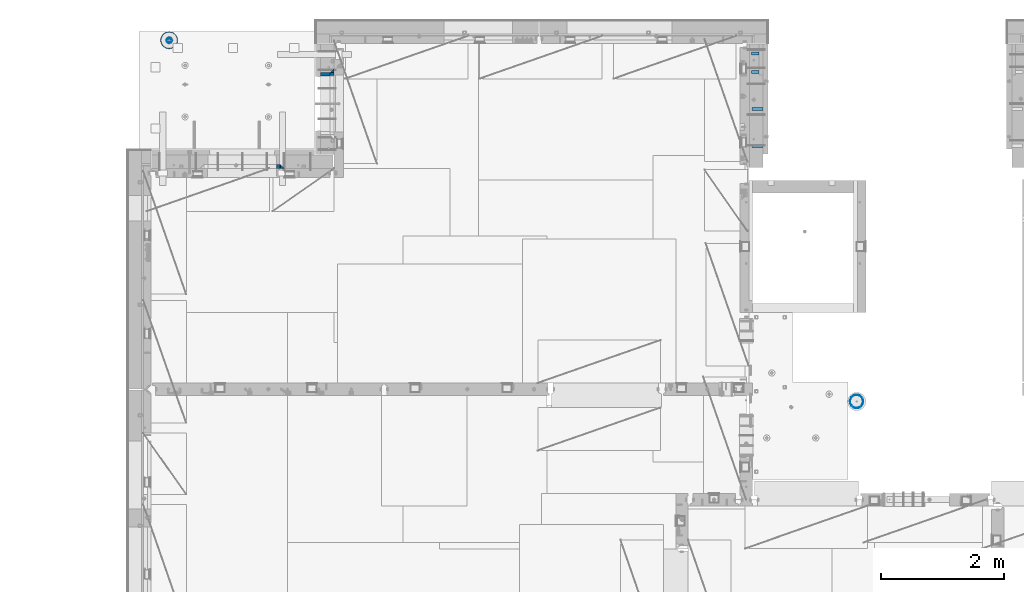
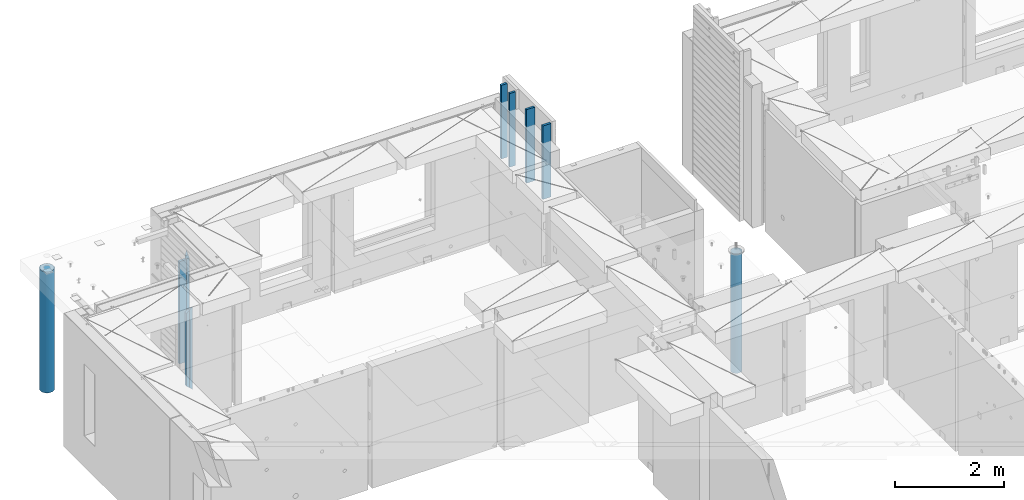
# One storey, part 4 of 309: 11 columns, 6 elements without a shape of their own.
"""IFC2X3 building model written with IfcOpenShell, lengths in millimetres."""

from ifc_helpers import new_model, si_unit, frame, origin_with_axes, place, context, subcontext, project, spatial, faceted_brep, material, type_object, element, aggregate, save


model = new_model("IFC2X3")

# Units and contexts
model_context = context("Model", 3, precision=1e-05, world=origin_with_axes())
body_context = subcontext(model_context, "Body", "Model", "MODEL_VIEW")
ifc_project = project(units=[si_unit("LENGTHUNIT", "METRE", prefix="MILLI"), si_unit("AREAUNIT", "SQUARE_METRE"), si_unit("VOLUMEUNIT", "CUBIC_METRE"), si_unit("MASSUNIT", "GRAM", prefix="KILO"), si_unit("TIMEUNIT", "SECOND"), si_unit("PLANEANGLEUNIT", "RADIAN"), si_unit("SOLIDANGLEUNIT", "STERADIAN"), si_unit("THERMODYNAMICTEMPERATUREUNIT", "DEGREE_CELSIUS"), si_unit("LUMINOUSINTENSITYUNIT", "LUMEN")], contexts=[model_context])

# Site, building, storey
site_placement = place(None, origin_with_axes())
site = spatial("IfcSite", under=ifc_project, at=site_placement, CompositionType="ELEMENT")
building_placement = place(site_placement, origin_with_axes())
building = spatial("IfcBuilding", under=site, at=building_placement, CompositionType="ELEMENT")
storey_placement = place(building_placement, origin_with_axes())
storey = spatial("IfcBuildingStorey", under=building, at=storey_placement, Name="7", CompositionType="ELEMENT", Elevation=0.0)

# Assembly, columns
assembly_1_placement = place(storey_placement, origin_with_axes())
assembly_1 = element("IfcElementAssembly", 1, at=assembly_1_placement, inside=storey, AssemblyPlace="NOTDEFINED", PredefinedType="REINFORCEMENT_UNIT")
ifc_material_1 = material(Name="CONCRETE/C25/30")
column_type_1 = type_object("IfcColumnType", PredefinedType="NOTDEFINED")
column_1_placement = place(assembly_1_placement, frame((10955.0, 22174.9998901814, 99755.0), z_axis=(0.0, -1.0, 0.0), x_axis=(0.0, 0.0, 1.0)))
column_1 = element("IfcColumn", 2, at=column_1_placement, type_object=column_type_1, material=ifc_material_1, Name="SK", context=body_context, shape_type="Brep", body=[
    faceted_brep([(0.0, -35.0, 35.0), (0.0, 35.0, 35.0), (0.0, -35.0, -35.0), (2420.0, -35.0, -35.0), (2349.99999999999, -35.0, 35.0), (2349.99999999999, 35.0, 35.0)], [[[0, 1, 2]], [[0, 2, 3, 4]], [[1, 0, 4, 5]], [[2, 1, 5, 3]], [[3, 5, 4]]]),
])
column_type_2 = type_object("IfcColumnType", PredefinedType="NOTDEFINED")
column_2_placement = place(assembly_1_placement, frame((10955.0, 22114.9998901814, 99755.0), z_axis=(0.0, -1.0, 0.0), x_axis=(0.0, 0.0, 1.0)))
column_2 = element("IfcColumn", 3, at=column_2_placement, type_object=column_type_2, material=ifc_material_1, Name="SK", context=body_context, shape_type="Brep", body=[
    faceted_brep([(0.0, 35.0, -25.0), (0.0, -35.0, -25.0), (0.0, -35.0, 18.8457723764259), (0.0, 35.0, 20.640644171297), (2350.0, -35.0, -25.0), (2306.15384615384, -35.0, 18.8457723764295), (2304.35897435897, 35.0, 20.6406441713007), (2350.0, 35.0, -25.0)], [[[0, 1, 2, 3]], [[2, 1, 4, 5]], [[3, 2, 5, 6]], [[0, 3, 6, 7]], [[7, 4, 1, 0]], [[4, 7, 6, 5]]]),
])
ifc_material_2 = material(Name="TIMBER")
column_type_3 = type_object("IfcColumnType", Name="50X150", PredefinedType="NOTDEFINED")
column_3_placement = place(assembly_1_placement, frame((10845.0, 22114.9998901814, 99760.0), z_axis=(0.0, -1.0, 0.0), x_axis=(0.0, 0.0, 1.0)))
column_3 = element("IfcColumn", 4, at=column_3_placement, type_object=column_type_3, material=ifc_material_2, ObjectType="50X150", context=body_context, shape_type="Brep", body=[
    faceted_brep([(0.0, 75.0, -25.0), (1.81898940354586e-12, 75.0, 25.0), (2295.00000000001, 75.0, 25.0), (2295.0, 75.0, -25.0), (1.81898940354586e-12, -75.0000000000009, 25.0), (2295.00000000001, -75.0, 25.0), (0.0, -75.0, -25.0), (2295.0, -75.0, -25.0)], [[[0, 1, 2, 3]], [[1, 4, 5, 2]], [[4, 6, 7, 5]], [[6, 0, 3, 7]], [[5, 7, 3, 2]], [[6, 4, 1, 0]]]),
])
aggregate(assembly_1, [column_1, column_2, column_3])

assembly_2_placement = place(storey_placement, origin_with_axes())
assembly_2 = element("IfcElementAssembly", 5, at=assembly_2_placement, inside=storey, AssemblyPlace="NOTDEFINED", PredefinedType="REINFORCEMENT_UNIT")
ifc_material_3 = material(Name="TIMBER/T24")
column_type_4 = type_object("IfcColumnType", Name="PK50X125", PredefinedType="NOTDEFINED")
column_4_placement = place(assembly_2_placement, frame((17857.5, 22455.0, 101690.0), z_axis=(-1.0, 3.00000001838171e-08, 0.0), x_axis=(0.0, 0.0, 1.0)))
column_4 = element("IfcColumn", 6, at=column_4_placement, type_object=column_type_4, material=ifc_material_3, ObjectType="PK50X125", context=body_context, shape_type="Brep", body=[
    faceted_brep([(0.0, 25.0, 62.5), (0.0, -25.0, 62.5), (1650.0, -25.0, 62.5), (1650.0, 25.0, 62.5), (0.0, -25.0, -62.5), (1650.0, -25.0, -62.5), (0.0, 25.0, -62.5), (1650.0, 25.0, -62.5)], [[[0, 1, 2, 3]], [[1, 4, 5, 2]], [[4, 6, 7, 5]], [[6, 0, 3, 7]], [[5, 7, 3, 2]], [[6, 4, 1, 0]]]),
])
column_5_placement = place(assembly_2_placement, frame((17857.5, 22150.0, 101690.0), z_axis=(-1.0, 3.00000001838171e-08, 0.0), x_axis=(0.0, 0.0, 1.0)))
column_5 = element("IfcColumn", 7, at=column_5_placement, type_object=column_type_4, material=ifc_material_3, ObjectType="PK50X125", context=body_context, shape_type="Brep", body=[
    faceted_brep([(0.0, 25.0, 62.5), (0.0, -25.0, 62.5), (1650.0, -25.0, 62.5), (1650.0, 25.0, 62.5), (0.0, -25.0, -62.5), (1650.0, -25.0, -62.5), (0.0, 25.0, -62.5), (1650.0, 25.0, -62.5)], [[[0, 1, 2, 3]], [[1, 4, 5, 2]], [[4, 6, 7, 5]], [[6, 0, 3, 7]], [[5, 7, 3, 2]], [[6, 4, 1, 0]]]),
])
column_type_5 = type_object("IfcColumnType", Name="PK50X175", PredefinedType="NOTDEFINED")
column_6_placement = place(assembly_2_placement, frame((17892.5, 21550.0, 101690.0), z_axis=(-1.0, 3.00000001838171e-08, 0.0), x_axis=(0.0, 0.0, 1.0)))
column_6 = element("IfcColumn", 8, at=column_6_placement, type_object=column_type_5, material=ifc_material_3, ObjectType="PK50X175", context=body_context, shape_type="Brep", body=[
    faceted_brep([(0.0, 25.0, 87.5), (0.0, -25.0, 87.5), (1650.0, -25.0, 87.5), (1650.0, 25.0, 87.5), (0.0, -25.0, -87.5), (1650.0, -25.0, -87.5), (0.0, 25.0, -87.5), (1650.0, 25.0, -87.5)], [[[0, 1, 2, 3]], [[1, 4, 5, 2]], [[4, 6, 7, 5]], [[6, 0, 3, 7]], [[5, 7, 3, 2]], [[6, 4, 1, 0]]]),
])
column_7_placement = place(assembly_2_placement, frame((17892.5, 20950.0, 101690.0), z_axis=(-1.0, 3.00000001838171e-08, 0.0), x_axis=(0.0, 0.0, 1.0)))
column_7 = element("IfcColumn", 9, at=column_7_placement, type_object=column_type_5, material=ifc_material_3, ObjectType="PK50X175", context=body_context, shape_type="Brep", body=[
    faceted_brep([(0.0, 25.0, 87.5), (0.0, -25.0, 87.5), (1650.0, -25.0, 87.5), (1650.0, 25.0, 87.5), (0.0, -25.0, -87.5), (1650.0, -25.0, -87.5), (0.0, 25.0, -87.5), (1650.0, 25.0, -87.5)], [[[0, 1, 2, 3]], [[1, 4, 5, 2]], [[4, 6, 7, 5]], [[6, 0, 3, 7]], [[5, 7, 3, 2]], [[6, 4, 1, 0]]]),
])
aggregate(assembly_2, [column_4, column_5, column_6, column_7])

assembly_3_placement = place(storey_placement, origin_with_axes())
assembly_3 = element("IfcElementAssembly", 10, at=assembly_3_placement, inside=storey, AssemblyPlace="NOTDEFINED", PredefinedType="REINFORCEMENT_UNIT")
column_type_6 = type_object("IfcColumnType", PredefinedType="NOTDEFINED")
column_8_placement = place(assembly_3_placement, frame((10144.9997107317, 20609.9951872276, 100320.0), z_axis=(-1.0, 3.00000001838171e-08, 0.0), x_axis=(0.0, 0.0, 1.0)))
column_8 = element("IfcColumn", 11, at=column_8_placement, type_object=column_type_6, material=ifc_material_1, Name="SK", context=body_context, shape_type="Brep", body=[
    faceted_brep([(1795.00000000001, -30.0, 30.0), (1855.0, -30.0, -30.0), (1795.00000000001, 30.0, 30.0), (0.0, -30.0, -30.0), (60.0000000000073, 30.0, 30.0), (60.0000000000073, -30.0, 30.0)], [[[0, 1, 2]], [[2, 1, 3, 4]], [[0, 2, 4, 5]], [[1, 0, 5, 3]], [[4, 3, 5]]]),
])
column_type_7 = type_object("IfcColumnType", PredefinedType="NOTDEFINED")
column_9_placement = place(assembly_3_placement, frame((10079.9997107317, 20609.9951872276, 100380.0), z_axis=(-1.0, 3.00000001838171e-08, 0.0), x_axis=(0.0, 0.0, 1.0)))
column_9 = element("IfcColumn", 12, at=column_9_placement, type_object=column_type_7, material=ifc_material_1, Name="SK", context=body_context, shape_type="Brep", body=[
    faceted_brep([(1678.70787161513, 29.999999998452, 30.6741497967687), (1680.09783300469, -29.999999998452, 29.0525281752307), (1735.0, -30.0, -35.0), (1735.0, 30.0, -35.0), (0.0, 30.0, -35.0), (56.29212838487, 29.999999998452, 30.6741497967687), (54.9021669952926, -29.999999998452, 29.0525281752307), (0.0, -30.0, -35.0)], [[[0, 1, 2, 3]], [[0, 3, 4, 5]], [[1, 0, 5, 6]], [[2, 1, 6, 7]], [[3, 2, 7, 4]], [[5, 4, 7, 6]]]),
])
aggregate(assembly_3, [column_8, column_9])

# Assemblies, column
assembly_4_placement = place(storey_placement, origin_with_axes())
assembly_4 = element("IfcElementAssembly", 13, at=assembly_4_placement, inside=storey, AssemblyPlace="NOTDEFINED", PredefinedType="NOTDEFINED")
assembly_5_placement = place(assembly_4_placement, origin_with_axes())
assembly_5 = element("IfcElementAssembly", 14, at=assembly_5_placement, Name="Steel Assembly", AssemblyPlace="NOTDEFINED", PredefinedType="RIGID_FRAME")
aggregate(assembly_4, [assembly_5])
ifc_material_4 = material(Name="STEEL/S355J2")
column_type_8 = type_object("IfcColumnType", Name="219.1X5", PredefinedType="NOTDEFINED")
column_10_placement = place(assembly_5_placement, frame((19510.0001169024, 16779.9976436332, 99790.0), z_axis=(-1.0, 3.00000001838171e-08, 0.0), x_axis=(0.0, 0.0, 1.0)))
column_10 = element("IfcColumn", 15, at=column_10_placement, type_object=column_type_8, material=ifc_material_4, ObjectType="219.1X5", context=body_context, shape_type="Brep", body=[
    faceted_brep([(0.0, -106.80335277952, 24.3771683149134), (0.0, -109.549999999999, 0.0), (2670.0, -109.549999999999, 0.0), (2670.0, -106.80335277952, 24.3771683149134), (0.0, -98.7011394787114, 47.5319636203276), (2670.0, -98.7011394787114, 47.5319636203276), (0.0, -85.6496389043714, 68.3033077936234), (2670.0, -85.6496389043714, 68.3033077936234), (0.0, -68.3033077936234, 85.6496389043714), (2670.0, -68.3033077936234, 85.6496389043714), (0.0, -47.5319636203276, 98.7011394787114), (2670.0, -47.5319636203276, 98.7011394787114), (0.0, -24.3771683149134, 106.80335277952), (2670.0, -24.3771683149134, 106.80335277952), (0.0, 0.0, 109.549999999999), (2670.0, 0.0, 109.549999999999), (0.0, 24.3771683149134, 106.80335277952), (2670.0, 24.3771683149134, 106.80335277952), (0.0, 47.5319636203276, 98.7011394787114), (2670.0, 47.5319636203276, 98.7011394787114), (0.0, 68.3033077936234, 85.6496389043714), (2670.0, 68.3033077936234, 85.6496389043714), (0.0, 85.6496389043714, 68.3033077936234), (2670.0, 85.6496389043714, 68.3033077936234), (0.0, 98.7011394787114, 47.5319636203276), (2670.0, 98.7011394787114, 47.5319636203276), (0.0, 106.80335277952, 24.3771683149134), (2670.0, 106.80335277952, 24.3771683149134), (0.0, 109.549999999999, 0.0), (2670.0, 109.549999999999, 0.0), (0.0, 106.80335277952, -24.3771683149134), (2670.0, 106.80335277952, -24.3771683149134), (0.0, 98.7011394787114, -47.5319636203276), (2670.0, 98.7011394787114, -47.5319636203276), (0.0, 85.6496389043714, -68.3033077936234), (2670.0, 85.6496389043714, -68.3033077936234), (0.0, 68.3033077936234, -85.6496389043714), (2670.0, 68.3033077936234, -85.6496389043714), (0.0, 47.5319636203276, -98.7011394787114), (2670.0, 47.5319636203276, -98.7011394787114), (0.0, 24.3771683149134, -106.80335277952), (2670.0, 24.3771683149134, -106.80335277952), (0.0, 0.0, -109.549999999999), (2670.0, 0.0, -109.549999999999), (0.0, -24.3771683149134, -106.80335277952), (2670.0, -24.3771683149134, -106.80335277952), (0.0, -47.5319636203276, -98.7011394787114), (2670.0, -47.5319636203276, -98.7011394787114), (0.0, -68.3033077936234, -85.6496389043714), (2670.0, -68.3033077936234, -85.6496389043714), (0.0, -85.6496389043714, -68.3033077936234), (2670.0, -85.6496389043714, -68.3033077936234), (0.0, -98.7011394787114, -47.5319636203276), (2670.0, -98.7011394787114, -47.5319636203276), (0.0, -106.80335277952, -24.3771683149134), (2670.0, -106.80335277952, -24.3771683149134), (0.0, -101.928713218611, -23.2645636451343), (0.0, -94.1962951391979, -45.3625449247411), (0.0, -81.7404814920337, -65.1858587843308), (0.0, -65.1858587843308, -81.7404814920337), (0.0, -45.3625449247411, -94.1962951391979), (0.0, -23.2645636451343, -101.928713218611), (0.0, 0.0, -104.549999999999), (0.0, 23.2645636451343, -101.928713218611), (0.0, 45.3625449247411, -94.1962951391979), (0.0, 65.1858587843308, -81.7404814920337), (0.0, 81.7404814920337, -65.1858587843308), (0.0, 94.1962951391979, -45.3625449247411), (0.0, 101.928713218611, -23.2645636451343), (0.0, 104.549999999999, 0.0), (0.0, 101.928713218611, 23.2645636451343), (0.0, 94.1962951391979, 45.3625449247411), (0.0, 81.7404814920337, 65.1858587843308), (0.0, 65.1858587843308, 81.7404814920337), (0.0, 45.3625449247411, 94.1962951391979), (0.0, 23.2645636451343, 101.928713218611), (0.0, 0.0, 104.549999999999), (0.0, -23.2645636451343, 101.928713218611), (0.0, -45.3625449247411, 94.1962951391979), (0.0, -65.1858587843308, 81.7404814920337), (0.0, -81.7404814920337, 65.1858587843308), (0.0, -94.1962951391979, 45.3625449247411), (0.0, -101.928713218611, 23.2645636451343), (0.0, -104.549999999999, 0.0), (2670.0, -101.928713218611, -23.2645636451343), (2670.0, -94.1962951391979, -45.3625449247411), (2670.0, -81.7404814920337, -65.1858587843308), (2670.0, -65.1858587843308, -81.7404814920337), (2670.0, -45.3625449247411, -94.1962951391979), (2670.0, -23.2645636451343, -101.928713218611), (2670.0, 0.0, -104.549999999999), (2670.0, 23.2645636451343, -101.928713218611), (2670.0, 45.3625449247411, -94.1962951391979), (2670.0, 65.1858587843308, -81.7404814920337), (2670.0, 81.7404814920337, -65.1858587843308), (2670.0, 94.1962951391979, -45.3625449247411), (2670.0, 101.928713218611, -23.2645636451343), (2670.0, 104.549999999999, 0.0), (2670.0, 101.928713218611, 23.2645636451343), (2670.0, 94.1962951391979, 45.3625449247411), (2670.0, 81.7404814920337, 65.1858587843308), (2670.0, 65.1858587843308, 81.7404814920337), (2670.0, 45.3625449247411, 94.1962951391979), (2670.0, 23.2645636451343, 101.928713218611), (2670.0, 0.0, 104.549999999999), (2670.0, -23.2645636451343, 101.928713218611), (2670.0, -45.3625449247411, 94.1962951391979), (2670.0, -65.1858587843308, 81.7404814920337), (2670.0, -81.7404814920337, 65.1858587843308), (2670.0, -94.1962951391979, 45.3625449247411), (2670.0, -101.928713218611, 23.2645636451343), (2670.0, -104.549999999999, 0.0)], [[[0, 1, 2, 3]], [[4, 0, 3, 5]], [[6, 4, 5, 7]], [[8, 6, 7, 9]], [[10, 8, 9, 11]], [[12, 10, 11, 13]], [[14, 12, 13, 15]], [[16, 14, 15, 17]], [[18, 16, 17, 19]], [[20, 18, 19, 21]], [[22, 20, 21, 23]], [[24, 22, 23, 25]], [[26, 24, 25, 27]], [[28, 26, 27, 29]], [[30, 28, 29, 31]], [[32, 30, 31, 33]], [[34, 32, 33, 35]], [[36, 34, 35, 37]], [[38, 36, 37, 39]], [[40, 38, 39, 41]], [[42, 40, 41, 43]], [[44, 42, 43, 45]], [[46, 44, 45, 47]], [[48, 46, 47, 49]], [[50, 48, 49, 51]], [[52, 50, 51, 53]], [[54, 52, 53, 55]], [[1, 54, 55, 2]], [[0, 4, 6, 8, 10, 12, 14, 16, 18, 20, 22, 24, 26, 28, 30, 32, 34, 36, 38, 40, 42, 44, 46, 48, 50, 52, 54, 1], [56, 57, 58, 59, 60, 61, 62, 63, 64, 65, 66, 67, 68, 69, 70, 71, 72, 73, 74, 75, 76, 77, 78, 79, 80, 81, 82, 83]], [[57, 56, 84, 85]], [[58, 57, 85, 86]], [[59, 58, 86, 87]], [[60, 59, 87, 88]], [[61, 60, 88, 89]], [[62, 61, 89, 90]], [[63, 62, 90, 91]], [[64, 63, 91, 92]], [[65, 64, 92, 93]], [[66, 65, 93, 94]], [[67, 66, 94, 95]], [[68, 67, 95, 96]], [[69, 68, 96, 97]], [[70, 69, 97, 98]], [[71, 70, 98, 99]], [[72, 71, 99, 100]], [[73, 72, 100, 101]], [[74, 73, 101, 102]], [[75, 74, 102, 103]], [[76, 75, 103, 104]], [[77, 76, 104, 105]], [[78, 77, 105, 106]], [[79, 78, 106, 107]], [[80, 79, 107, 108]], [[81, 80, 108, 109]], [[82, 81, 109, 110]], [[83, 82, 110, 111]], [[53, 51, 49, 47, 45, 43, 41, 39, 37, 35, 33, 31, 29, 27, 25, 23, 21, 19, 17, 15, 13, 11, 9, 7, 5, 3, 2, 55], [109, 108, 107, 106, 105, 104, 103, 102, 101, 100, 99, 98, 97, 96, 95, 94, 93, 92, 91, 90, 89, 88, 87, 86, 85, 84, 111, 110]], [[56, 83, 111, 84]]]),
])
aggregate(assembly_5, [column_10])

# Assembly, column
assembly_6_placement = place(storey_placement, origin_with_axes())
assembly_6 = element("IfcElementAssembly", 16, at=assembly_6_placement, inside=storey, AssemblyPlace="NOTDEFINED", PredefinedType="REINFORCEMENT_UNIT")
ifc_material_5 = material(Name="CONCRETE/C30/37")
column_type_9 = type_object("IfcColumnType", Name="D280", PredefinedType="NOTDEFINED")
column_11_placement = place(assembly_6_placement, frame((8299.99879520436, 22669.984888838, 99725.0), z_axis=(-1.0, 3.00000001838171e-08, 0.0), x_axis=(0.0, 0.0, 1.0)))
column_11 = element("IfcColumn", 17, at=column_11_placement, type_object=column_type_9, material=ifc_material_5, ObjectType="D280", context=body_context, shape_type="Brep", body=[
    faceted_brep([(0.0, -140.0, 0.0), (0.0, -136.489907705454, -31.1529307538876), (2710.0, -136.489907705454, -31.1529307538876), (2710.0, -140.0, 0.0), (0.0, -126.135641506338, -60.7437234764584), (2710.0, -126.135641506338, -60.7437234764584), (0.0, -109.456407545524, -87.2885722602223), (2710.0, -109.456407545524, -87.2885722602223), (0.0, -87.2885722602223, -109.456407545527), (2710.0, -87.2885722602223, -109.456407545527), (0.0, -60.7437234764584, -126.135641506342), (2710.0, -60.7437234764584, -126.135641506342), (0.0, -31.152930753884, -136.489907705458), (2710.0, -31.152930753884, -136.489907705458), (0.0, 0.0, -140.0), (2710.0, 0.0, -140.0), (0.0, 31.152930753884, -136.489907705458), (2710.0, 31.152930753884, -136.489907705458), (0.0, 60.7437234764584, -126.135641506342), (2710.0, 60.7437234764584, -126.135641506342), (0.0, 87.2885722602223, -109.456407545527), (2710.0, 87.2885722602223, -109.456407545527), (0.0, 109.456407545524, -87.2885722602223), (2710.0, 109.456407545524, -87.2885722602223), (0.0, 126.135641506338, -60.7437234764584), (2710.0, 126.135641506338, -60.7437234764584), (0.0, 136.489907705454, -31.1529307538876), (2710.0, 136.489907705454, -31.1529307538876), (0.0, 140.0, 0.0), (2710.0, 140.0, 0.0), (0.0, 136.489907705454, 31.1529307538876), (2710.0, 136.489907705454, 31.1529307538876), (0.0, 126.135641506338, 60.7437234764584), (2710.0, 126.135641506338, 60.7437234764584), (0.0, 109.456407545524, 87.2885722602223), (2710.0, 109.456407545524, 87.2885722602223), (0.0, 87.2885722602223, 109.456407545527), (2710.0, 87.2885722602223, 109.456407545527), (0.0, 60.7437234764584, 126.135641506342), (2710.0, 60.7437234764584, 126.135641506342), (0.0, 31.152930753884, 136.489907705458), (2710.0, 31.152930753884, 136.489907705458), (0.0, 0.0, 140.0), (2710.0, 0.0, 140.0), (0.0, -31.152930753884, 136.489907705458), (2710.0, -31.152930753884, 136.489907705458), (0.0, -60.7437234764584, 126.135641506342), (2710.0, -60.7437234764584, 126.135641506342), (0.0, -87.2885722602223, 109.456407545527), (2710.0, -87.2885722602223, 109.456407545527), (0.0, -109.456407545524, 87.2885722602223), (2710.0, -109.456407545524, 87.2885722602223), (0.0, -126.135641506338, 60.7437234764584), (2710.0, -126.135641506338, 60.7437234764584), (0.0, -136.489907705454, 31.1529307538876), (2710.0, -136.489907705454, 31.1529307538876)], [[[0, 1, 2, 3]], [[1, 4, 5, 2]], [[4, 6, 7, 5]], [[6, 8, 9, 7]], [[8, 10, 11, 9]], [[10, 12, 13, 11]], [[12, 14, 15, 13]], [[14, 16, 17, 15]], [[16, 18, 19, 17]], [[18, 20, 21, 19]], [[20, 22, 23, 21]], [[22, 24, 25, 23]], [[24, 26, 27, 25]], [[26, 28, 29, 27]], [[28, 30, 31, 29]], [[30, 32, 33, 31]], [[32, 34, 35, 33]], [[34, 36, 37, 35]], [[36, 38, 39, 37]], [[38, 40, 41, 39]], [[40, 42, 43, 41]], [[42, 44, 45, 43]], [[44, 46, 47, 45]], [[46, 48, 49, 47]], [[48, 50, 51, 49]], [[50, 52, 53, 51]], [[52, 54, 55, 53]], [[54, 0, 3, 55]], [[5, 7, 9, 11, 13, 15, 17, 19, 21, 23, 25, 27, 29, 31, 33, 35, 37, 39, 41, 43, 45, 47, 49, 51, 53, 55, 3, 2]], [[54, 52, 50, 48, 46, 44, 42, 40, 38, 36, 34, 32, 30, 28, 26, 24, 22, 20, 18, 16, 14, 12, 10, 8, 6, 4, 1, 0]]]),
])
aggregate(assembly_6, [column_11])

save(model, "model.ifc")
